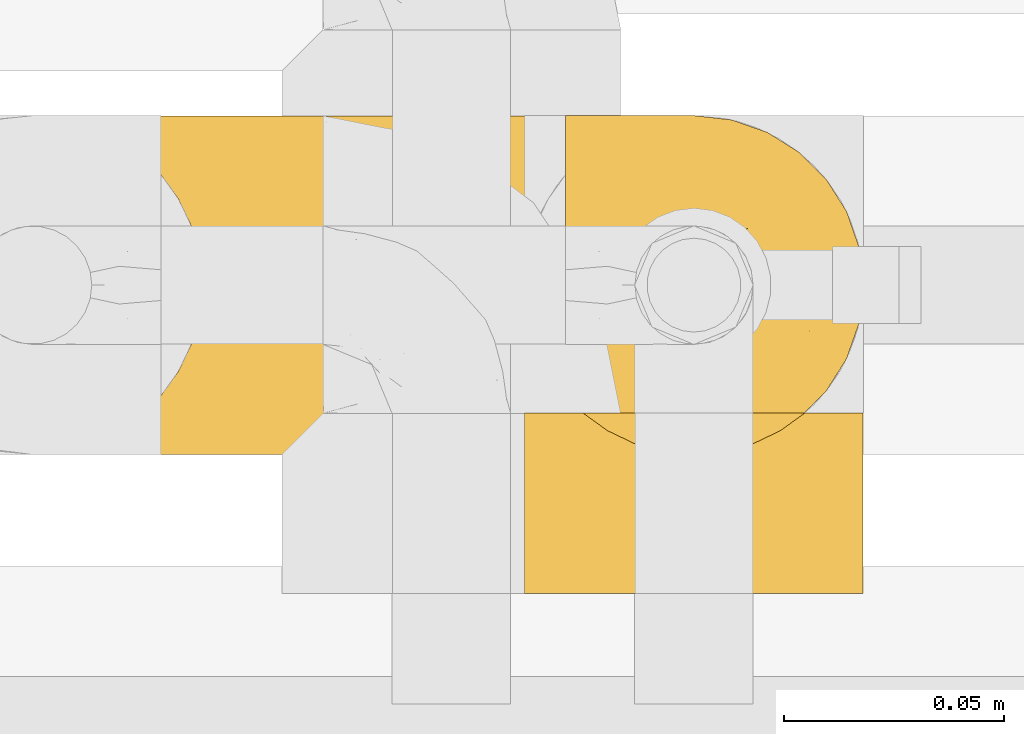
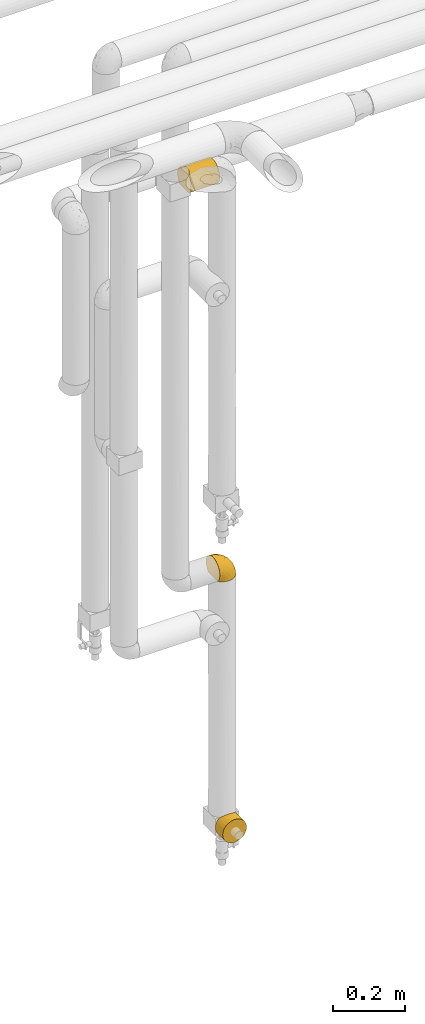
# One storey, part 330 of 827: 3 coverings.
"""IFC2X3 building model written with IfcOpenShell, lengths in millimetres."""

from ifc_helpers import new_model, entity, si_unit, converted_unit, derived_unit, direction, frame, origin, place, context, subcontext, project, spatial, faceted_brep, element, save


model = new_model("IFC2X3")

# Units and contexts
model_context = context("Model", 3, precision=0.01, world=origin(), true_north=direction((6.12303176911189e-17, 1.0)))
body_context = subcontext(model_context, "Body", "Model", "MODEL_VIEW")
ifc_project = project(units=[si_unit("LENGTHUNIT", "METRE", prefix="MILLI"), si_unit("AREAUNIT", "SQUARE_METRE"), si_unit("VOLUMEUNIT", "CUBIC_METRE"), converted_unit("PLANEANGLEUNIT", "DEGREE", entity("IfcRatioMeasure", 0.0174532925199433), si_unit("PLANEANGLEUNIT", "RADIAN"), dimensions=[0, 0, 0, 0, 0, 0, 0]), si_unit("MASSUNIT", "GRAM", prefix="KILO"), derived_unit("MASSDENSITYUNIT", [(si_unit("MASSUNIT", "GRAM", prefix="KILO"), 1), (si_unit("LENGTHUNIT", "METRE"), -3)]), derived_unit("MOMENTOFINERTIAUNIT", [(si_unit("LENGTHUNIT", "METRE"), 4)]), si_unit("TIMEUNIT", "SECOND"), si_unit("FREQUENCYUNIT", "HERTZ"), si_unit("THERMODYNAMICTEMPERATUREUNIT", "DEGREE_CELSIUS"), derived_unit("THERMALTRANSMITTANCEUNIT", [(si_unit("MASSUNIT", "GRAM", prefix="KILO"), 1), (si_unit("THERMODYNAMICTEMPERATUREUNIT", "KELVIN"), -1), (si_unit("TIMEUNIT", "SECOND"), -3)]), derived_unit("VOLUMETRICFLOWRATEUNIT", [(si_unit("LENGTHUNIT", "METRE"), 3), (si_unit("TIMEUNIT", "SECOND"), -1)]), derived_unit("MASSFLOWRATEUNIT", [(si_unit("MASSUNIT", "GRAM", prefix="KILO"), 1), (si_unit("TIMEUNIT", "SECOND"), -1)]), derived_unit("ROTATIONALFREQUENCYUNIT", [(si_unit("TIMEUNIT", "SECOND"), -1)]), si_unit("ELECTRICCURRENTUNIT", "AMPERE"), si_unit("ELECTRICVOLTAGEUNIT", "VOLT"), si_unit("POWERUNIT", "WATT"), si_unit("FORCEUNIT", "NEWTON", prefix="KILO"), si_unit("ILLUMINANCEUNIT", "LUX"), si_unit("LUMINOUSFLUXUNIT", "LUMEN"), si_unit("LUMINOUSINTENSITYUNIT", "CANDELA"), derived_unit("USERDEFINED", [(si_unit("MASSUNIT", "GRAM", prefix="KILO"), -1), (si_unit("LENGTHUNIT", "METRE"), -2), (si_unit("TIMEUNIT", "SECOND"), 3), (si_unit("LUMINOUSFLUXUNIT", "LUMEN"), 1)]), derived_unit("LINEARVELOCITYUNIT", [(si_unit("LENGTHUNIT", "METRE"), 1), (si_unit("TIMEUNIT", "SECOND"), -1)]), si_unit("PRESSUREUNIT", "PASCAL"), derived_unit("USERDEFINED", [(si_unit("LENGTHUNIT", "METRE"), -2), (si_unit("MASSUNIT", "GRAM", prefix="KILO"), 1), (si_unit("TIMEUNIT", "SECOND"), -2)]), derived_unit("LINEARFORCEUNIT", [(si_unit("MASSUNIT", "GRAM", prefix="KILO"), 1), (si_unit("LENGTHUNIT", "METRE"), 1), (si_unit("TIMEUNIT", "SECOND"), -2), (si_unit("LENGTHUNIT", "METRE"), -1)]), derived_unit("PLANARFORCEUNIT", [(si_unit("MASSUNIT", "GRAM", prefix="KILO"), 1), (si_unit("LENGTHUNIT", "METRE"), 1), (si_unit("TIMEUNIT", "SECOND"), -2), (si_unit("LENGTHUNIT", "METRE"), -2)])], contexts=[model_context])

# Site, building, storey
site_placement = place(None, origin())
site = spatial("IfcSite", under=ifc_project, at=site_placement, CompositionType="ELEMENT")
building_placement = place(site_placement, origin())
building = spatial("IfcBuilding", under=site, at=building_placement, CompositionType="ELEMENT")
storey_placement = place(building_placement, frame((0.0, 0.0, 28200.0)))
storey = spatial("IfcBuildingStorey", under=building, at=storey_placement, Name="08", CompositionType="ELEMENT", Elevation=28200.0)

# Coverings
covering_1_placement = place(storey_placement, frame((34809.73, 18294.87, 1199.3)))
element("IfcCovering", 1, at=covering_1_placement, inside=storey, Name=":ADSK_", ObjectType=":ADSK_", PredefinedType="INSULATION", context=body_context, shape_type="Brep", body=[
    faceted_brep([(47.38, 74.68, 1.6), (54.67, 70.1, 1.6), (60.76, 64.01, 1.6), (65.34, 56.72, 1.6), (68.18, 48.6, 1.6), (69.15, 40.05, 1.6), (68.18, 31.49, 1.6), (65.33, 23.36, 1.6), (60.75, 16.07, 1.6), (54.66, 9.98, 1.6), (47.37, 5.4, 1.6), (39.25, 2.56, 1.6), (30.7, 1.6, 1.6), (22.59, 2.46, 1.6), (14.86, 5.01, 1.6), (7.84, 9.13, 1.6), (1.85, 14.62, 1.6), (1.85, 16.82, 1.6), (1.85, 18.56, 1.6), (1.85, 20.52, 1.6), (1.85, 22.49, 1.6), (1.85, 24.46, 1.6), (1.85, 26.42, 1.6), (1.85, 28.39, 1.6), (1.85, 30.36, 1.6), (1.85, 32.55, 1.6), (1.85, 34.75, 1.6), (1.85, 36.94, 1.6), (1.85, 39.13, 1.6), (1.85, 41.33, 1.6), (1.85, 43.52, 1.6), (1.85, 45.72, 1.6), (1.85, 47.91, 1.6), (1.85, 50.11, 1.6), (1.85, 52.3, 1.6), (1.85, 54.49, 1.6), (1.85, 56.69, 1.6), (1.85, 58.88, 1.6), (1.85, 61.08, 1.6), (1.85, 63.27, 1.6), (1.85, 65.47, 1.6), (7.85, 70.97, 1.6), (14.88, 75.09, 1.6), (22.61, 77.64, 1.6), (30.7, 78.5, 1.6), (39.26, 77.53, 1.6), (1.6, 14.62, 1.85), (1.6, 9.12, 7.85), (1.6, 5.0, 14.87), (1.6, 2.46, 22.6), (1.6, 1.6, 30.7), (1.6, 2.91, 40.65), (1.6, 6.75, 49.92), (1.6, 12.86, 57.88), (1.6, 20.82, 63.99), (1.6, 30.09, 67.84), (1.6, 40.05, 69.15), (1.6, 50.0, 67.84), (1.6, 59.27, 63.99), (1.6, 67.23, 57.88), (1.6, 73.34, 49.92), (1.6, 77.19, 40.65), (1.6, 78.5, 30.7), (1.6, 77.63, 22.6), (1.6, 75.09, 14.87), (1.6, 70.97, 7.85), (1.6, 65.47, 1.85), (1.6, 63.27, 1.85), (1.6, 62.29, 1.85), (1.6, 60.7, 1.85), (1.6, 59.11, 1.85), (1.6, 57.52, 1.85), (1.6, 55.93, 1.85), (1.6, 54.34, 1.85), (1.6, 52.76, 1.85), (1.6, 51.17, 1.85), (1.6, 49.58, 1.85), (1.6, 47.99, 1.85), (1.6, 46.4, 1.85), (1.6, 44.81, 1.85), (1.6, 43.22, 1.85), (1.6, 41.63, 1.85), (1.6, 40.05, 1.85), (1.6, 38.46, 1.85), (1.6, 36.87, 1.85), (1.6, 35.28, 1.85), (1.6, 33.69, 1.85), (1.6, 32.1, 1.85), (1.6, 30.51, 1.85), (1.6, 28.92, 1.85), (1.6, 27.33, 1.85), (1.6, 25.37, 1.85), (1.6, 23.4, 1.85), (1.6, 21.21, 1.85), (1.6, 19.01, 1.85), (1.6, 16.82, 1.85), (1.78, 42.32, 1.77), (1.77, 44.02, 1.78), (1.78, 47.13, 1.77), (1.77, 48.74, 1.77), (1.79, 23.57, 1.76), (1.78, 25.13, 1.77), (1.76, 61.34, 1.79), (1.77, 22.02, 1.78), (1.77, 29.72, 1.78), (1.76, 56.73, 1.78), (1.77, 55.14, 1.78), (1.77, 37.66, 1.78), (1.8, 64.12, 1.74), (1.76, 28.13, 1.78), (1.77, 26.62, 1.78), (1.78, 31.46, 1.77), (1.77, 16.16, 1.78), (1.77, 39.16, 1.78), (1.76, 50.37, 1.78), (1.77, 17.69, 1.77), (1.78, 19.17, 1.77), (1.77, 62.78, 1.77), (1.77, 58.35, 1.78), (1.77, 45.53, 1.78), (1.78, 59.91, 1.77), (1.77, 65.47, 1.77), (1.8, 65.47, 1.72), (1.82, 65.47, 1.66), (1.77, 14.62, 1.77), (1.72, 14.62, 1.8), (1.66, 14.62, 1.82), (1.76, 20.59, 1.79), (1.77, 32.99, 1.78), (1.76, 34.48, 1.79), (1.77, 51.91, 1.78), (1.66, 65.47, 1.82), (1.72, 65.47, 1.8), (1.78, 53.48, 1.76), (1.82, 14.62, 1.66), (1.8, 14.62, 1.72), (1.77, 40.77, 1.78), (1.78, 35.97, 1.77), (3.72, 7.84, 9.41), (7.41, 3.53, 17.65), (6.13, 8.32, 7.41), (21.47, 1.6, 21.47), (19.34, 2.19, 15.21), (26.8, 1.6, 16.15), (8.87, 1.6, 28.75), (9.2, 4.57, 13.67), (12.79, 3.96, 12.79), (14.62, 2.28, 19.18), (7.34, 1.6, 29.16), (5.33, 7.69, 9.04), (17.64, 3.53, 7.41), (7.7, 8.32, 5.74), (9.41, 7.84, 3.72), (28.75, 1.6, 8.87), (16.15, 1.6, 26.8), (14.14, 4.34, 9.53), (29.16, 1.6, 7.34), (57.02, 29.63, 37.63), (64.92, 27.34, 17.92), (64.0, 40.05, 27.45), (11.92, 2.39, 37.01), (19.16, 2.43, 34.22), (28.65, 9.07, 45.87), (24.62, 16.64, 56.57), (15.19, 9.54, 52.31), (18.36, 4.52, 42.07), (9.2, 4.52, 44.74), (46.98, 7.49, 21.49), (50.24, 7.49, 11.02), (56.1, 12.85, 15.64), (28.97, 2.35, 26.02), (54.46, 22.66, 36.59), (21.34, 32.9, 65.49), (18.4, 25.33, 63.99), (66.44, 40.05, 15.2), (12.07, 16.64, 60.27), (45.49, 19.99, 45.25), (50.57, 16.37, 35.21), (36.04, 3.26, 22.52), (42.07, 3.75, 12.03), (62.12, 19.58, 13.32), (37.37, 7.5, 35.9), (29.39, 4.04, 33.87), (53.59, 13.94, 25.73), (58.06, 19.58, 26.34), (49.27, 28.21, 46.78), (29.63, 24.75, 59.54), (33.21, 31.42, 60.18), (40.1, 26.2, 53.93), (44.08, 33.36, 53.36), (49.36, 40.05, 49.36), (56.68, 40.05, 38.4), (15.2, 40.05, 66.44), (35.57, 16.14, 50.09), (41.7, 12.85, 41.08), (46.4, 10.47, 31.14), (41.41, 6.49, 28.19), (27.45, 40.05, 64.0), (38.4, 40.05, 56.68), (12.99, 75.57, 43.9), (21.33, 47.37, 65.46), (42.89, 52.91, 52.22), (57.04, 50.46, 37.61), (56.11, 67.23, 15.64), (62.13, 60.5, 13.31), (21.89, 70.55, 50.02), (16.62, 63.45, 59.28), (32.9, 62.61, 53.05), (46.99, 72.6, 21.48), (50.25, 72.6, 11.01), (42.08, 76.34, 12.03), (49.91, 59.34, 41.02), (15.6, 77.76, 35.39), (16.15, 78.5, 26.8), (8.87, 78.5, 28.75), (29.16, 78.5, 7.34), (13.16, 53.16, 65.81), (10.83, 70.55, 53.28), (33.8, 48.88, 59.8), (25.02, 54.76, 61.82), (64.92, 52.74, 17.91), (32.83, 71.93, 41.4), (20.56, 75.79, 40.48), (58.07, 60.5, 26.34), (21.46, 77.86, 31.68), (28.1, 77.64, 27.68), (26.8, 78.5, 16.15), (21.47, 78.5, 21.47), (51.29, 67.23, 28.05), (36.04, 76.82, 22.54), (28.75, 78.5, 8.87), (8.45, 77.8, 37.3), (41.73, 67.23, 41.07), (39.27, 73.2, 32.24), (33.56, 67.66, 47.4), (27.29, 75.99, 35.77), (7.41, 76.57, 17.65), (3.51, 73.21, 11.06), (4.68, 71.93, 8.55), (5.52, 71.07, 6.63), (8.75, 75.09, 12.77), (12.79, 76.13, 12.79), (17.65, 76.57, 7.41), (13.9, 77.69, 18.97), (9.42, 72.26, 3.72), (7.68, 71.77, 5.76), (19.33, 77.9, 15.21), (14.13, 75.75, 9.52)], [[[0, 1, 2, 3, 4, 5, 6, 7, 8, 9, 10, 11, 12, 13, 14, 15, 16, 17, 18, 19, 20, 21, 22, 23, 24, 25, 26, 27, 28, 29, 30, 31, 32, 33, 34, 35, 36, 37, 38, 39, 40, 41, 42, 43, 44, 45]], [[46, 47, 48, 49, 50, 51, 52, 53, 54, 55, 56, 57, 58, 59, 60, 61, 62, 63, 64, 65, 66, 67, 68, 69, 70, 71, 72, 73, 74, 75, 76, 77, 78, 79, 80, 81, 82, 83, 84, 85, 86, 87, 88, 89, 90, 91, 92, 93, 94, 95]], [[96, 97, 30]], [[98, 77, 99]], [[100, 101, 21]], [[69, 68, 102]], [[20, 19, 103]], [[24, 23, 104]], [[20, 103, 100]], [[72, 105, 106]], [[84, 83, 107]], [[89, 88, 104]], [[108, 67, 66]], [[109, 110, 90]], [[111, 25, 24]], [[112, 17, 16]], [[82, 113, 83]], [[109, 23, 22]], [[114, 76, 75]], [[105, 36, 106]], [[104, 111, 24]], [[18, 115, 116]], [[97, 96, 80]], [[67, 108, 117]], [[105, 71, 118]], [[31, 97, 119]], [[102, 120, 69]], [[108, 121, 122, 123, 40]], [[112, 95, 115]], [[17, 115, 18]], [[94, 116, 115]], [[117, 68, 67]], [[38, 117, 39]], [[112, 124, 125, 126, 46]], [[17, 112, 115]], [[70, 120, 118]], [[39, 117, 108]], [[120, 38, 37]], [[120, 37, 118]], [[120, 70, 69]], [[116, 94, 127]], [[128, 86, 129]], [[117, 38, 102]], [[74, 130, 75]], [[99, 33, 32]], [[115, 95, 94]], [[39, 108, 40]], [[108, 66, 131, 132, 121]], [[105, 72, 71]], [[118, 37, 36]], [[71, 70, 118]], [[35, 106, 36]], [[36, 105, 118]], [[35, 133, 106]], [[74, 73, 133]], [[106, 133, 73]], [[99, 114, 33]], [[133, 35, 34]], [[73, 72, 106]], [[95, 112, 46]], [[112, 16, 134, 135, 124]], [[130, 114, 75]], [[99, 76, 114]], [[114, 130, 33]], [[34, 33, 130]], [[78, 77, 98]], [[98, 119, 78]], [[130, 133, 34]], [[133, 130, 74]], [[79, 97, 80]], [[98, 99, 32]], [[98, 32, 31]], [[77, 76, 99]], [[97, 79, 119]], [[136, 96, 29]], [[30, 97, 31]], [[136, 29, 28]], [[81, 80, 96]], [[29, 96, 30]], [[31, 119, 98]], [[119, 79, 78]], [[96, 136, 81]], [[82, 81, 136]], [[113, 107, 83]], [[84, 107, 137]], [[107, 27, 137]], [[113, 28, 107]], [[27, 107, 28]], [[85, 84, 137]], [[137, 27, 26]], [[113, 136, 28]], [[136, 113, 82]], [[109, 89, 104]], [[86, 85, 129]], [[89, 109, 90]], [[111, 87, 128]], [[26, 129, 137]], [[88, 111, 104]], [[25, 111, 128]], [[22, 110, 109]], [[23, 109, 104]], [[110, 91, 90]], [[100, 92, 101]], [[110, 22, 101]], [[91, 110, 101]], [[116, 19, 18]], [[111, 88, 87]], [[127, 103, 19]], [[25, 128, 26]], [[86, 128, 87]], [[128, 129, 26]], [[137, 129, 85]], [[120, 102, 38]], [[117, 102, 68]], [[91, 101, 92]], [[21, 101, 22]], [[93, 92, 103]], [[100, 21, 20]], [[100, 103, 92]], [[127, 93, 103]], [[93, 127, 94]], [[116, 127, 19]], [[126, 138, 47]], [[48, 138, 139]], [[140, 125, 124]], [[141, 142, 143]], [[144, 49, 139]], [[145, 140, 146]], [[48, 139, 49]], [[139, 145, 147]], [[49, 144, 148, 50]], [[126, 125, 149]], [[14, 13, 150]], [[151, 146, 140]], [[149, 140, 145]], [[152, 151, 135]], [[152, 14, 150]], [[16, 15, 134]], [[13, 153, 150]], [[124, 151, 140]], [[141, 147, 142]], [[14, 152, 15]], [[15, 152, 134]], [[47, 46, 126]], [[139, 154, 144]], [[138, 48, 47]], [[125, 140, 149]], [[135, 134, 152]], [[146, 155, 142]], [[145, 146, 147]], [[149, 139, 138]], [[147, 141, 154]], [[147, 146, 142]], [[139, 147, 154]], [[139, 149, 145]], [[149, 138, 126]], [[155, 146, 151]], [[150, 143, 142]], [[152, 155, 151]], [[150, 142, 155]], [[13, 12, 156, 153]], [[153, 143, 150]], [[152, 150, 155]], [[151, 124, 135]], [[157, 158, 159]], [[160, 154, 161]], [[162, 163, 164]], [[165, 166, 160]], [[167, 168, 169]], [[141, 170, 161]], [[156, 12, 11]], [[158, 157, 171]], [[172, 55, 173]], [[158, 6, 174]], [[175, 54, 53]], [[52, 166, 164]], [[52, 164, 53]], [[54, 175, 173]], [[166, 52, 51]], [[176, 177, 171]], [[178, 143, 179]], [[156, 11, 179]], [[8, 7, 180]], [[169, 9, 8]], [[179, 143, 153, 156]], [[179, 11, 10]], [[168, 179, 10]], [[181, 162, 182]], [[179, 167, 178]], [[183, 184, 177]], [[183, 169, 184]], [[176, 171, 185]], [[172, 186, 187]], [[158, 7, 6]], [[159, 158, 174]], [[184, 180, 158]], [[54, 173, 55]], [[180, 169, 8]], [[188, 189, 187]], [[9, 168, 10]], [[186, 188, 187]], [[190, 157, 159, 191]], [[55, 172, 192]], [[176, 193, 194]], [[161, 170, 182]], [[162, 164, 165]], [[175, 164, 163]], [[51, 50, 148]], [[167, 195, 196]], [[178, 182, 170]], [[6, 5, 174]], [[158, 180, 7]], [[169, 180, 184]], [[169, 168, 9]], [[179, 168, 167]], [[182, 162, 165]], [[162, 194, 193]], [[161, 165, 160]], [[195, 181, 196]], [[192, 172, 197]], [[192, 56, 55]], [[189, 190, 198]], [[198, 197, 187]], [[172, 187, 197]], [[185, 189, 188]], [[198, 187, 189]], [[186, 172, 173]], [[173, 163, 186]], [[193, 186, 163]], [[176, 185, 188]], [[185, 157, 190]], [[188, 186, 193]], [[177, 176, 194]], [[188, 193, 176]], [[162, 193, 163]], [[195, 177, 194]], [[171, 177, 184]], [[181, 195, 194]], [[183, 167, 169]], [[162, 181, 194]], [[196, 182, 178]], [[158, 171, 184]], [[171, 157, 185]], [[177, 195, 183]], [[167, 183, 195]], [[182, 196, 181]], [[178, 170, 143]], [[178, 167, 196]], [[164, 175, 53]], [[173, 175, 163]], [[160, 51, 148]], [[164, 166, 165]], [[51, 160, 166]], [[160, 148, 144, 154]], [[141, 161, 154]], [[182, 165, 161]], [[190, 189, 185]], [[143, 170, 141]], [[60, 199, 61]], [[197, 200, 192]], [[201, 190, 202]], [[200, 57, 192]], [[203, 204, 2]], [[205, 206, 207]], [[208, 209, 210]], [[211, 207, 201]], [[212, 213, 214]], [[45, 215, 210]], [[216, 206, 58]], [[45, 44, 215]], [[59, 217, 60]], [[60, 217, 199]], [[0, 45, 210]], [[218, 201, 219]], [[202, 159, 220]], [[205, 221, 222]], [[223, 204, 203]], [[1, 203, 2]], [[57, 200, 216]], [[220, 3, 204]], [[220, 174, 4]], [[1, 0, 209]], [[212, 224, 213]], [[225, 226, 227]], [[228, 223, 203]], [[208, 210, 229]], [[210, 226, 229]], [[3, 220, 4]], [[58, 206, 59]], [[209, 203, 1]], [[202, 220, 223]], [[228, 203, 208]], [[202, 211, 201]], [[3, 2, 204]], [[202, 190, 191, 159]], [[210, 215, 230, 226]], [[199, 212, 231]], [[232, 233, 221]], [[233, 208, 229]], [[207, 206, 219]], [[217, 206, 205]], [[227, 224, 225]], [[233, 232, 228]], [[201, 207, 219]], [[234, 232, 221]], [[218, 219, 200]], [[202, 223, 211]], [[174, 220, 159]], [[174, 5, 4]], [[61, 231, 62]], [[220, 204, 223]], [[210, 209, 0]], [[203, 209, 208]], [[225, 233, 229]], [[224, 227, 213]], [[221, 233, 235]], [[57, 56, 192]], [[198, 218, 197]], [[200, 219, 216]], [[201, 198, 190]], [[197, 218, 200]], [[198, 201, 218]], [[206, 216, 219]], [[58, 57, 216]], [[231, 212, 214]], [[222, 212, 199]], [[228, 211, 223]], [[207, 211, 232]], [[62, 231, 214]], [[199, 231, 61]], [[233, 228, 208]], [[211, 228, 232]], [[222, 221, 235]], [[234, 205, 207]], [[206, 217, 59]], [[199, 217, 205]], [[205, 222, 199]], [[224, 222, 235]], [[222, 224, 212]], [[224, 235, 225]], [[233, 225, 235]], [[226, 225, 229]], [[205, 234, 221]], [[207, 232, 234]], [[63, 214, 236]], [[214, 213, 236]], [[214, 63, 62]], [[237, 236, 238]], [[238, 132, 131]], [[236, 237, 64]], [[239, 240, 241]], [[63, 236, 64]], [[131, 66, 65]], [[237, 131, 65]], [[242, 230, 43]], [[237, 65, 64]], [[239, 121, 132]], [[42, 242, 43]], [[241, 240, 243]], [[41, 123, 244]], [[43, 230, 215, 44]], [[244, 122, 245]], [[227, 246, 243]], [[241, 247, 245]], [[121, 239, 245]], [[41, 40, 123]], [[132, 238, 239]], [[244, 42, 41]], [[131, 237, 238]], [[240, 239, 238]], [[245, 239, 241]], [[247, 241, 246]], [[247, 244, 245]], [[238, 236, 240]], [[243, 236, 213]], [[236, 243, 240]], [[227, 226, 246]], [[243, 213, 227]], [[242, 246, 226]], [[243, 246, 241]], [[246, 242, 247]], [[244, 247, 242]], [[242, 226, 230]], [[42, 244, 242]], [[122, 244, 123]], [[122, 121, 245]]]),
])
covering_2_placement = place(storey_placement, frame((34800.43, 18264.91, 332.0)))
element("IfcCovering", 2, at=covering_2_placement, inside=storey, Name=":ADSK_", ObjectType=":ADSK_", PredefinedType="INSULATION", context=body_context, shape_type="Brep", body=[
    faceted_brep([(5.06, 41.0, 55.94), (9.24, 41.0, 62.99), (14.82, 41.0, 69.0), (65.17, 41.0, 69.0), (70.75, 41.0, 62.99), (74.93, 41.0, 55.94), (77.52, 41.0, 48.16), (78.4, 41.0, 40.0), (77.09, 41.0, 30.06), (73.25, 41.0, 20.8), (67.15, 41.0, 12.84), (59.2, 41.0, 6.74), (49.93, 41.0, 2.9), (40.0, 41.0, 1.6), (30.06, 41.0, 2.9), (20.8, 41.0, 6.74), (12.84, 41.0, 12.84), (6.74, 41.0, 20.8), (2.9, 41.0, 30.06), (1.6, 41.0, 40.0), (2.47, 41.0, 48.16), (20.8, 0.0, 73.25), (12.84, 0.0, 67.15), (6.74, 0.0, 59.2), (2.9, 0.0, 49.93), (1.6, 0.0, 40.0), (2.9, 0.0, 30.06), (6.74, 0.0, 20.8), (12.84, 0.0, 12.84), (20.8, 0.0, 6.74), (30.06, 0.0, 2.9), (40.0, 0.0, 1.6), (49.93, 0.0, 2.9), (59.2, 0.0, 6.74), (67.15, 0.0, 12.84), (73.25, 0.0, 20.8), (77.09, 0.0, 30.06), (78.4, 0.0, 40.0), (77.09, 0.0, 49.93), (73.25, 0.0, 59.2), (67.15, 0.0, 67.15), (59.2, 0.0, 73.25), (49.93, 0.0, 77.09), (40.0, 0.0, 78.4), (30.06, 0.0, 77.09), (26.56, 34.03, 75.97), (33.17, 32.21, 77.78), (40.0, 31.6, 78.4), (20.38, 36.99, 73.01), (46.82, 32.21, 77.78), (53.43, 34.03, 75.97), (59.61, 36.99, 73.01)], [[[0, 1, 2, 3, 4, 5, 6, 7, 8, 9, 10, 11, 12, 13, 14, 15, 16, 17, 18, 19, 20]], [[21, 22, 23, 24, 25, 26, 27, 28, 29, 30, 31, 32, 33, 34, 35, 36, 37, 38, 39, 40, 41, 42, 43, 44]], [[7, 37, 36, 8]], [[8, 36, 35, 9]], [[10, 9, 35, 34]], [[12, 11, 33, 32]], [[13, 12, 32, 31]], [[34, 33, 11, 10]], [[13, 31, 30, 14]], [[14, 30, 29, 15]], [[28, 16, 15, 29]], [[18, 17, 27, 26]], [[19, 18, 26, 25]], [[28, 27, 17, 16]], [[25, 24, 20]], [[23, 22, 1]], [[24, 23, 0]], [[19, 25, 20]], [[1, 0, 23]], [[24, 0, 20]], [[22, 2, 1]], [[45, 21, 44]], [[44, 43, 46]], [[47, 46, 43]], [[2, 22, 48]], [[46, 45, 44]], [[48, 21, 45]], [[48, 22, 21]], [[49, 47, 43]], [[49, 43, 42]], [[50, 42, 41]], [[50, 49, 42]], [[40, 3, 51]], [[50, 41, 51]], [[51, 41, 40]], [[4, 40, 39]], [[5, 39, 38]], [[6, 38, 37]], [[4, 39, 5]], [[5, 38, 6]], [[37, 7, 6]], [[40, 4, 3]], [[48, 45, 46, 47, 49, 50, 51, 3, 2]]]),
])
covering_3_placement = place(storey_placement, frame((34717.83, 18294.92, 2540.0)))
element("IfcCovering", 3, at=covering_3_placement, inside=storey, Name=":ADSK_", ObjectType=":ADSK_", PredefinedType="INSULATION", context=body_context, shape_type="Brep", body=[
    faceted_brep([(93.5, 77.51, 31.79), (93.5, 78.4, 40.0), (93.5, 77.09, 49.93), (93.5, 73.25, 59.2), (93.5, 67.15, 67.15), (93.5, 59.2, 73.25), (93.5, 49.93, 77.09), (93.5, 40.0, 78.4), (93.5, 30.06, 77.09), (93.5, 20.8, 73.25), (93.5, 12.84, 67.15), (93.5, 6.74, 59.2), (93.5, 2.9, 49.93), (93.5, 1.6, 40.0), (93.5, 2.48, 31.79), (93.5, 5.09, 23.98), (93.5, 9.31, 16.91), (93.5, 14.94, 10.9), (93.5, 65.05, 10.9), (93.5, 70.68, 16.91), (93.5, 74.9, 23.98), (1.6, 78.4, 40.0), (1.6, 77.52, 31.83), (1.6, 74.93, 24.05), (1.6, 70.75, 17.0), (1.6, 65.17, 11.0), (1.6, 14.82, 11.0), (1.6, 9.24, 17.0), (1.6, 5.06, 24.05), (1.6, 2.47, 31.83), (1.6, 1.6, 40.0), (1.6, 2.47, 48.16), (1.6, 5.06, 55.94), (1.6, 9.24, 62.99), (1.6, 14.82, 69.0), (1.6, 65.17, 69.0), (1.6, 70.75, 62.99), (1.6, 74.93, 55.94), (1.6, 77.52, 48.16), (5.61, 20.38, 6.98), (8.57, 26.56, 4.02), (89.52, 20.48, 6.92), (10.38, 33.17, 2.21), (11.0, 40.0, 1.6), (84.8, 33.21, 2.2), (86.6, 26.63, 4.0), (84.2, 40.0, 1.6), (10.38, 46.82, 2.21), (84.8, 46.78, 2.2), (8.57, 53.43, 4.02), (5.61, 59.61, 6.98), (89.52, 59.51, 6.92), (86.6, 53.36, 4.0), (5.61, 59.61, 73.01), (8.57, 53.43, 75.97), (10.38, 46.82, 77.78), (11.0, 40.0, 78.4), (10.38, 33.17, 77.78), (8.57, 26.56, 75.97), (5.61, 20.38, 73.01)], [[[0, 1, 2, 3, 4, 5, 6, 7, 8, 9, 10, 11, 12, 13, 14, 15, 16, 17, 18, 19, 20]], [[21, 22, 23, 24, 25, 26, 27, 28, 29, 30, 31, 32, 33, 34, 35, 36, 37, 38]], [[30, 29, 13]], [[27, 26, 16]], [[13, 29, 14]], [[27, 15, 28]], [[15, 27, 16]], [[28, 15, 14]], [[29, 28, 14]], [[26, 17, 16]], [[39, 40, 41]], [[42, 43, 44]], [[40, 42, 45]], [[41, 17, 39]], [[44, 45, 42]], [[46, 44, 43]], [[41, 40, 45]], [[39, 17, 26]], [[43, 47, 48]], [[49, 50, 51]], [[47, 49, 52]], [[48, 46, 43]], [[51, 52, 49]], [[18, 51, 50]], [[48, 47, 52]], [[50, 25, 18]], [[20, 24, 23]], [[0, 23, 22]], [[1, 22, 21]], [[25, 19, 18]], [[25, 24, 19]], [[20, 19, 24]], [[23, 0, 20]], [[22, 1, 0]], [[1, 21, 38]], [[2, 38, 37]], [[3, 37, 36]], [[1, 38, 2]], [[2, 37, 3]], [[36, 4, 3]], [[36, 35, 4]], [[35, 53, 5]], [[54, 55, 6]], [[53, 54, 5]], [[5, 54, 6]], [[7, 6, 55]], [[56, 7, 55]], [[35, 5, 4]], [[57, 58, 8]], [[59, 34, 9]], [[58, 59, 9]], [[56, 57, 7]], [[7, 57, 8]], [[58, 9, 8]], [[34, 10, 9]], [[11, 33, 32]], [[12, 32, 31]], [[13, 31, 30]], [[10, 33, 11]], [[11, 32, 12]], [[31, 13, 12]], [[33, 10, 34]], [[48, 52, 51, 18, 17, 41, 45, 44, 46]], [[34, 59, 58, 57, 56, 55, 54, 53, 35]], [[25, 50, 49, 47, 43, 42, 40, 39, 26]]]),
])

save(model, "model.ifc")
